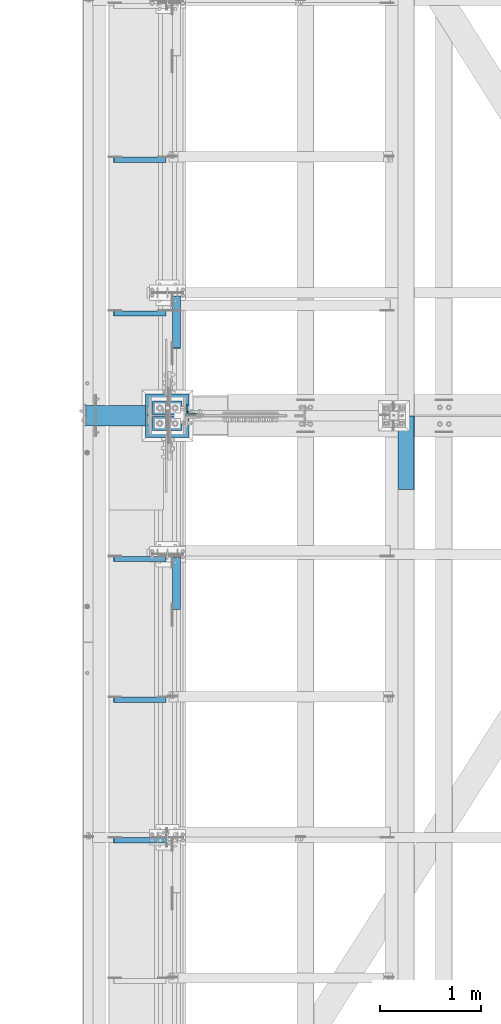
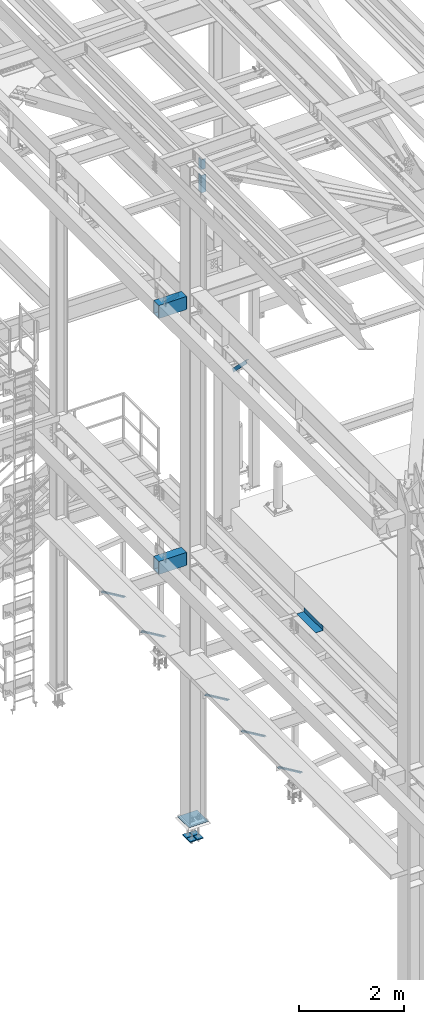
# One storey, part 2400 of 3843: 10 beams, 7 members, 11 elements without a shape of their own.
"""IFC2X3 building model written with IfcOpenShell, lengths in millimetres."""

from ifc_helpers import new_model, si_unit, frame, origin_with_axes, place, context, subcontext, project, spatial, faceted_brep, material, type_object, element, aggregate, save


model = new_model("IFC2X3")

# Units and contexts
model_context = context("Model", 3, precision=1e-05, world=origin_with_axes())
body_context = subcontext(model_context, "Body", "Model", "MODEL_VIEW")
ifc_project = project(units=[si_unit("LENGTHUNIT", "METRE", prefix="MILLI"), si_unit("AREAUNIT", "SQUARE_METRE"), si_unit("VOLUMEUNIT", "CUBIC_METRE"), si_unit("MASSUNIT", "GRAM", prefix="KILO"), si_unit("TIMEUNIT", "SECOND"), si_unit("PLANEANGLEUNIT", "RADIAN"), si_unit("SOLIDANGLEUNIT", "STERADIAN"), si_unit("THERMODYNAMICTEMPERATUREUNIT", "DEGREE_CELSIUS"), si_unit("LUMINOUSINTENSITYUNIT", "LUMEN")], contexts=[model_context])

# Site, building, storey
site_placement = place(None, origin_with_axes())
site = spatial("IfcSite", under=ifc_project, at=site_placement, CompositionType="ELEMENT")
building_placement = place(site_placement, origin_with_axes())
building = spatial("IfcBuilding", under=site, at=building_placement, Name="Undefined", CompositionType="ELEMENT")
storey_placement = place(building_placement, origin_with_axes())
storey = spatial("IfcBuildingStorey", under=building, at=storey_placement, Name="Undefined", CompositionType="ELEMENT", Elevation=0.0)

# Assembly, beam
assembly_1_placement = place(storey_placement, origin_with_axes())
assembly_1 = element("IfcElementAssembly", 1, at=assembly_1_placement, inside=storey, Name="BEAM", AssemblyPlace="NOTDEFINED", PredefinedType="RIGID_FRAME")
ifc_material_1 = material(Name="STEEL/A36")
beam_type_1 = type_object("IfcBeamType", PredefinedType="NOTDEFINED")
beam_1_placement = place(assembly_1_placement, frame((38858.825, 83616.8, 34039.175), z_axis=(0.0, -1.0, 0.0), x_axis=(1.0, 0.0, 0.0)))
beam_1 = element("IfcBeam", 2, at=beam_1_placement, type_object=beam_type_1, material=ifc_material_1, Name="BENT_PLATE", context=body_context, shape_type="Brep", body=[
    faceted_brep([(161.925005912773, 7.27595761418343e-12, 365.125000000029), (158.749999999993, 3.17500000000291, 361.950000000041), (0.0, 3.17500000000291, 361.950000000041), (0.0, 0.0, 365.125), (161.924999999988, 98.4249999999956, 365.125), (158.749999999993, 98.4249999999956, 361.950000000041), (165.099999999999, -3.17500000000291, -365.125), (0.0, -3.17500000000291, -365.125), (0.0, 3.17500000000291, -365.125), (158.749999999993, 3.17500000000291, -365.125), (158.749999999993, 98.4249999999956, -365.125), (165.099999999999, 98.4249999999956, -365.125), (165.099999999999, -3.17500000000291, 365.125), (165.099999999999, 98.4249999999956, 365.125), (0.0, -3.17500000000291, 365.125)], [[[0, 1, 2, 3]], [[4, 5, 1, 0]], [[6, 7, 8, 9, 10, 11]], [[12, 6, 11, 13]], [[14, 7, 6, 12]], [[8, 7, 14, 3, 2]], [[9, 8, 2, 1]], [[10, 9, 1, 5]], [[13, 11, 10, 5, 4]], [[14, 12, 13, 4, 0, 3]]]),
])
aggregate(assembly_1, [beam_1])

# Assembly, member
assembly_2_placement = place(storey_placement, origin_with_axes())
assembly_2 = element("IfcElementAssembly", 3, at=assembly_2_placement, inside=storey, Name="ANGLE", AssemblyPlace="NOTDEFINED", PredefinedType="RIGID_FRAME")
ifc_material_2 = material(Name="STEEL/A572-50")
member_type_1 = type_object("IfcMemberType", Name="L2X2X1/4", PredefinedType="NOTDEFINED")
member_1_placement = place(assembly_2_placement, frame((36032.7062481198, 86521.9250000001, 34001.5027629153), z_axis=(0.0, -1.0, 0.0), x_axis=(0.858158898344811, 0.0, -0.513384169206278)))
member_1 = element("IfcMember", 4, at=member_1_placement, type_object=member_type_1, material=ifc_material_2, Name="ANGLE", ObjectType="L2X2X1/4", context=body_context, shape_type="Brep", body=[
    faceted_brep([(0.0, 25.4000000000015, -25.4000000000015), (0.0, 25.4000000000015, 25.4000000000015), (598.473132324763, 25.3999999988228, 25.3999999999942), (598.473132324763, 25.3999999988228, -25.3999999999942), (0.0, 19.0500000000029, 25.4000000000015), (598.473132324745, 19.0499999988242, 25.3999999999942), (0.0, 19.0500000000029, -19.0499999999993), (598.473132324745, 19.0499999988242, -19.0500000000029), (0.0, -25.4000000000015, -19.0499999999993), (598.473132324661, -25.4000000011511, -19.0500000000029), (0.0, -25.4000000000015, -25.4000000000015), (598.473132324661, -25.4000000011511, -25.3999999999942)], [[[0, 1, 2, 3]], [[1, 4, 5, 2]], [[4, 6, 7, 5]], [[6, 8, 9, 7]], [[8, 10, 11, 9]], [[10, 0, 3, 11]], [[5, 7, 9, 11, 3, 2]], [[10, 8, 6, 4, 1, 0]]]),
])
aggregate(assembly_2, [member_1])

assembly_3_placement = place(storey_placement, origin_with_axes())
assembly_3 = element("IfcElementAssembly", 5, at=assembly_3_placement, inside=storey, Name="ANGLE", AssemblyPlace="NOTDEFINED", PredefinedType="RIGID_FRAME")
member_2_placement = place(assembly_3_placement, frame((36032.7062481198, 84997.9250000001, 34001.5027629153), z_axis=(0.0, -1.0, 0.0), x_axis=(0.858158898344811, 0.0, -0.513384169206278)))
member_2 = element("IfcMember", 6, at=member_2_placement, type_object=member_type_1, material=ifc_material_2, Name="ANGLE", ObjectType="L2X2X1/4", context=body_context, shape_type="Brep", body=[
    faceted_brep([(0.0, 25.4000000000015, -25.4000000000015), (0.0, 25.4000000000015, 25.4000000000015), (598.473132324763, 25.3999999988228, 25.3999999999942), (598.473132324763, 25.3999999988228, -25.3999999999942), (0.0, 19.0500000000029, 25.4000000000015), (598.473132324745, 19.0499999988242, 25.3999999999942), (0.0, 19.0500000000029, -19.0499999999993), (598.473132324745, 19.0499999988242, -19.0500000000029), (0.0, -25.4000000000015, -19.0499999999993), (598.473132324661, -25.4000000011511, -19.0500000000029), (0.0, -25.4000000000015, -25.4000000000015), (598.473132324661, -25.4000000011511, -25.3999999999942)], [[[0, 1, 2, 3]], [[1, 4, 5, 2]], [[4, 6, 7, 5]], [[6, 8, 9, 7]], [[8, 10, 11, 9]], [[10, 0, 3, 11]], [[5, 7, 9, 11, 3, 2]], [[10, 8, 6, 4, 1, 0]]]),
])
aggregate(assembly_3, [member_2])

assembly_4_placement = place(storey_placement, origin_with_axes())
assembly_4 = element("IfcElementAssembly", 7, at=assembly_4_placement, inside=storey, Name="ANGLE", AssemblyPlace="NOTDEFINED", PredefinedType="RIGID_FRAME")
member_3_placement = place(assembly_4_placement, frame((36032.7062481198, 82563.6921880001, 34001.5027629153), z_axis=(0.0, -1.0, 0.0), x_axis=(0.858158898344811, 0.0, -0.513384169206278)))
member_3 = element("IfcMember", 8, at=member_3_placement, type_object=member_type_1, material=ifc_material_2, Name="ANGLE", ObjectType="L2X2X1/4", context=body_context, shape_type="Brep", body=[
    faceted_brep([(0.0, 25.4000000000015, -25.4000000000015), (0.0, 25.4000000000015, 25.4000000000015), (598.473132324763, 25.3999999988228, 25.3999999999942), (598.473132324763, 25.3999999988228, -25.3999999999942), (0.0, 19.0500000000029, 25.4000000000015), (598.473132324745, 19.0499999988242, 25.3999999999942), (0.0, 19.0500000000029, -19.0499999999993), (598.473132324745, 19.0499999988242, -19.0500000000029), (0.0, -25.4000000000015, -19.0499999999993), (598.473132324661, -25.4000000011511, -19.0500000000029), (0.0, -25.4000000000015, -25.4000000000015), (598.473132324661, -25.4000000011511, -25.3999999999942)], [[[0, 1, 2, 3]], [[1, 4, 5, 2]], [[4, 6, 7, 5]], [[6, 8, 9, 7]], [[8, 10, 11, 9]], [[10, 0, 3, 11]], [[5, 7, 9, 11, 3, 2]], [[10, 8, 6, 4, 1, 0]]]),
])
aggregate(assembly_4, [member_3])

assembly_5_placement = place(storey_placement, origin_with_axes())
assembly_5 = element("IfcElementAssembly", 9, at=assembly_5_placement, inside=storey, Name="ANGLE", AssemblyPlace="NOTDEFINED", PredefinedType="RIGID_FRAME")
member_4_placement = place(assembly_5_placement, frame((36032.7062481198, 81170.8593760001, 34001.5027629153), z_axis=(0.0, -1.0, 0.0), x_axis=(0.858158898344811, 0.0, -0.513384169206278)))
member_4 = element("IfcMember", 10, at=member_4_placement, type_object=member_type_1, material=ifc_material_2, Name="ANGLE", ObjectType="L2X2X1/4", context=body_context, shape_type="Brep", body=[
    faceted_brep([(0.0, 25.4000000000015, -25.4000000000015), (0.0, 25.4000000000015, 25.4000000000015), (598.473132324763, 25.3999999988228, 25.3999999999942), (598.473132324763, 25.3999999988228, -25.3999999999942), (0.0, 19.0500000000029, 25.4000000000015), (598.473132324745, 19.0499999988242, 25.3999999999942), (0.0, 19.0500000000029, -19.0499999999993), (598.473132324745, 19.0499999988242, -19.0500000000029), (0.0, -25.4000000000015, -19.0499999999993), (598.473132324661, -25.4000000011511, -19.0500000000029), (0.0, -25.4000000000015, -25.4000000000015), (598.473132324661, -25.4000000011511, -25.3999999999942)], [[[0, 1, 2, 3]], [[1, 4, 5, 2]], [[4, 6, 7, 5]], [[6, 8, 9, 7]], [[8, 10, 11, 9]], [[10, 0, 3, 11]], [[5, 7, 9, 11, 3, 2]], [[10, 8, 6, 4, 1, 0]]]),
])
aggregate(assembly_5, [member_4])

assembly_6_placement = place(storey_placement, origin_with_axes())
assembly_6 = element("IfcElementAssembly", 11, at=assembly_6_placement, inside=storey, Name="ANGLE", AssemblyPlace="NOTDEFINED", PredefinedType="RIGID_FRAME")
member_5_placement = place(assembly_6_placement, frame((36032.7062481198, 79778.1257820001, 34001.5027629153), z_axis=(0.0, -1.0, 0.0), x_axis=(0.858158898344811, 0.0, -0.513384169206278)))
member_5 = element("IfcMember", 12, at=member_5_placement, type_object=member_type_1, material=ifc_material_2, Name="ANGLE", ObjectType="L2X2X1/4", context=body_context, shape_type="Brep", body=[
    faceted_brep([(0.0, 25.4000000000015, -25.4000000000015), (0.0, 25.4000000000015, 25.4000000000015), (598.473132324763, 25.3999999988228, 25.3999999999942), (598.473132324763, 25.3999999988228, -25.3999999999942), (0.0, 19.0500000000029, 25.4000000000015), (598.473132324745, 19.0499999988242, 25.3999999999942), (0.0, 19.0500000000029, -19.0499999999993), (598.473132324745, 19.0499999988242, -19.0500000000029), (0.0, -25.4000000000015, -19.0499999999993), (598.473132324661, -25.4000000011511, -19.0500000000029), (0.0, -25.4000000000015, -25.4000000000015), (598.473132324661, -25.4000000011511, -25.3999999999942)], [[[0, 1, 2, 3]], [[1, 4, 5, 2]], [[4, 6, 7, 5]], [[6, 8, 9, 7]], [[8, 10, 11, 9]], [[10, 0, 3, 11]], [[5, 7, 9, 11, 3, 2]], [[10, 8, 6, 4, 1, 0]]]),
])
aggregate(assembly_6, [member_5])

# Assembly, beams
assembly_7_placement = place(storey_placement, origin_with_axes())
assembly_7 = element("IfcElementAssembly", 13, at=assembly_7_placement, inside=storey, Name="COLUMN", AssemblyPlace="NOTDEFINED", PredefinedType="RIGID_FRAME")
ifc_material_3 = material()
beam_type_2 = type_object("IfcBeamType", Name="HSS12X8X3/8", PredefinedType="NOTDEFINED")
beam_2_placement = place(assembly_7_placement, frame((35760.025, 83985.1, 42214.8), z_axis=(0.0, 0.0, 1.0), x_axis=(1.0, 0.0, 0.0)))
beam_2 = element("IfcBeam", 14, at=beam_2_placement, type_object=beam_type_2, material=ifc_material_3, Name="GIRT", ObjectType="HSS12X8X3/8", context=body_context, shape_type="Brep", body=[
    faceted_brep([(625.474999999999, 92.0749999999971, 142.875), (625.474999999999, 92.0749999999971, -142.875), (615.949999999997, 101.600000000006, -152.400000000001), (615.949999999997, 101.600000000006, 152.400000000001), (625.474999999999, -92.0749999999971, -142.875), (615.949999999997, -101.600000000006, -152.400000000001), (625.474999999999, -92.0749999999971, 142.875), (615.949999999997, -101.600000000006, 152.400000000001), (6.35000000002037, 92.0749999999971, 142.875), (6.35000000002037, 92.0749999999971, -142.875), (6.35000000002037, -92.0749999999971, 142.875), (6.35000000002037, -92.0749999999971, -142.875), (6.35000000002037, -101.600000000006, -152.400000000001), (6.35000000002037, -101.600000000006, 152.400000000001), (6.35000000002037, 101.600000000006, 152.400000000001), (6.35000000002037, 101.600000000006, -152.400000000001)], [[[0, 1, 2, 3]], [[4, 5, 2, 1]], [[6, 7, 5, 4]], [[8, 9, 1, 0]], [[10, 8, 0, 6]], [[11, 10, 6, 4]], [[9, 11, 4, 1]], [[12, 13, 14, 15], [8, 10, 11, 9]], [[15, 14, 3, 2]], [[12, 15, 2, 5]], [[13, 12, 5, 7]], [[14, 13, 7, 3]], [[0, 3, 7, 6]]]),
])
beam_3_placement = place(assembly_7_placement, frame((35760.025, 83985.1, 36252.15), z_axis=(0.0, 0.0, 1.0), x_axis=(1.0, 0.0, 0.0)))
beam_3 = element("IfcBeam", 15, at=beam_3_placement, type_object=beam_type_2, material=ifc_material_3, Name="BEAM", ObjectType="HSS12X8X3/8", context=body_context, shape_type="Brep", body=[
    faceted_brep([(625.474999999999, 92.0749999999971, 142.875), (625.474999999999, 92.0749999999971, -142.875), (615.949999999997, 101.600000000006, -152.400000000001), (615.949999999997, 101.600000000006, 152.400000000001), (625.474999999999, -92.0749999999971, -142.875), (615.949999999997, -101.600000000006, -152.400000000001), (625.474999999999, -92.0749999999971, 142.875), (615.949999999997, -101.600000000006, 152.400000000001), (6.35000000002037, 92.0749999999971, 142.875), (6.35000000002037, 92.0749999999971, -142.875), (6.35000000002037, -92.0749999999971, 142.875), (6.35000000002037, -92.0749999999971, -142.875), (6.35000000002037, -101.600000000006, -152.400000000001), (6.35000000002037, -101.600000000006, 152.400000000001), (6.35000000002037, 101.600000000006, 152.400000000001), (6.35000000002037, 101.600000000006, -152.400000000001)], [[[0, 1, 2, 3]], [[4, 5, 2, 1]], [[6, 7, 5, 4]], [[8, 9, 1, 0]], [[10, 8, 0, 6]], [[11, 10, 6, 4]], [[9, 11, 4, 1]], [[12, 13, 14, 15], [8, 10, 11, 9]], [[15, 14, 3, 2]], [[12, 15, 2, 5]], [[13, 12, 5, 7]], [[14, 13, 7, 3]], [[0, 3, 7, 6]]]),
])
aggregate(assembly_7, [beam_2, beam_3])

assembly_8_placement = place(storey_placement, origin_with_axes())
assembly_8 = element("IfcElementAssembly", 16, at=assembly_8_placement, inside=storey, Name="BEAM", AssemblyPlace="NOTDEFINED", PredefinedType="RIGID_FRAME")
beam_type_3 = type_object("IfcBeamType", Name="L4X4X5/8", PredefinedType="NOTDEFINED")
beam_4_placement = place(assembly_8_placement, frame((36810.95, 84045.4249996185, 44978.4221334664), z_axis=(0.0, 1.0, 0.0), x_axis=(0.0, 0.0, -1.0)))
beam_4 = element("IfcBeam", 17, at=beam_4_placement, type_object=beam_type_3, material=ifc_material_2, Name="ANGLE", ObjectType="L4X4X5/8", context=body_context, shape_type="Brep", body=[
    faceted_brep([(0.0, 50.8000000000029, -50.8000000000029), (0.0, 50.8000000000029, 50.8000000000029), (406.399999999841, 50.799999998344, 50.8000000000029), (406.399999999841, 50.799999998344, -50.8000000000029), (0.0, 34.9250000000029, 50.8000000000029), (406.399999999892, 34.924999998344, 50.8000000000029), (0.0, 34.9250000000029, -34.9250000000029), (406.399999999892, 34.924999998344, -34.9250000000029), (0.0, -50.8000000000029, -34.9250000000029), (406.400000000162, -50.8000000016473, -34.9250000000029), (0.0, -50.8000000000029, -50.8000000000029), (406.400000000162, -50.8000000016473, -50.8000000000029)], [[[0, 1, 2, 3]], [[1, 4, 5, 2]], [[4, 6, 7, 5]], [[6, 8, 9, 7]], [[8, 10, 11, 9]], [[10, 0, 3, 11]], [[5, 7, 9, 11, 3, 2]], [[10, 8, 6, 4, 1, 0]]]),
])
beam_5_placement = place(assembly_8_placement, frame((36810.9499999688, 84047.0120004654, 45342.1750030886), z_axis=(0.0, 1.0, 0.0), x_axis=(0.0, 0.0, -1.0)))
beam_5 = element("IfcBeam", 18, at=beam_5_placement, type_object=beam_type_3, material=ifc_material_2, Name="ANGLE", ObjectType="L4X4X5/8", context=body_context, shape_type="Brep", body=[
    faceted_brep([(0.0, 50.8000000000029, -50.8000000000029), (0.0, 50.8000000000029, 50.8000000000029), (228.600164820818, 50.8000000000029, 50.8000000000029), (228.600164820818, 50.8000000000029, -50.8000000000029), (0.0, 34.9250000000029, 50.8000000000029), (228.600164820818, 34.9250000000029, 50.8000000000029), (0.0, 34.9250000000029, -34.9250000000029), (228.600164820818, 34.9250000000029, -34.9250000000029), (0.0, -50.8000000000029, -34.9250000000029), (228.600164820818, -50.8000000000029, -34.9250000000029), (0.0, -50.8000000000029, -50.8000000000029), (228.600164820818, -50.8000000000029, -50.8000000000029)], [[[0, 1, 2, 3]], [[1, 4, 5, 2]], [[4, 6, 7, 5]], [[6, 8, 9, 7]], [[8, 10, 11, 9]], [[10, 0, 3, 11]], [[5, 7, 9, 11, 3, 2]], [[10, 8, 6, 4, 1, 0]]]),
])
aggregate(assembly_8, [beam_4, beam_5])

# Assembly, member
assembly_9_placement = place(storey_placement, origin_with_axes())
assembly_9 = element("IfcElementAssembly", 19, at=assembly_9_placement, inside=storey, Name="ANGLE", AssemblyPlace="NOTDEFINED", PredefinedType="RIGID_FRAME")
member_type_2 = type_object("IfcMemberType", Name="L3X3X1/4", PredefinedType="NOTDEFINED")
member_6_placement = place(assembly_9_placement, frame((36664.9, 82613.5, 41300.4), z_axis=(0.0, -0.707106781186548, -0.707106781186548), x_axis=(0.0, -0.707106781186682, 0.707106781186413)))
member_6 = element("IfcMember", 20, at=member_6_placement, type_object=member_type_2, material=ifc_material_2, Name="ANGLE", ObjectType="L3X3X1/4", context=body_context, shape_type="Brep", body=[
    faceted_brep([(83.0012806675732, 38.0999999999985, -38.0999999999058), (83.0012806675732, -38.0999999999985, -38.0999999999058), (83.0012806675804, -38.0999999999985, -31.7499999999254), (83.0012806675804, 31.75, -31.7499999999254), (83.0012806675804, 31.75, 38.0999999999058), (83.0012806675804, 38.0999999999985, 38.0999999999058), (810.534203444928, 31.75, 38.0999999999112), (810.534203444928, 38.0999999999985, 38.0999999999112), (810.534203444538, 38.0999999999985, -38.099999999904), (810.534203444538, -38.0999999999985, -38.099999999904), (810.534203444575, -38.0999999999985, -31.7499999999272), (810.534203444575, 31.75, -31.7499999999272)], [[[0, 1, 2, 3, 4, 5]], [[5, 4, 6, 7]], [[0, 5, 7, 8]], [[1, 0, 8, 9]], [[2, 1, 9, 10]], [[3, 2, 10, 11]], [[4, 3, 11, 6]], [[10, 9, 8, 7, 6, 11]]]),
])
aggregate(assembly_9, [member_6])

assembly_10_placement = place(storey_placement, origin_with_axes())
assembly_10 = element("IfcElementAssembly", 21, at=assembly_10_placement, inside=storey, Name="ANGLE", AssemblyPlace="NOTDEFINED", PredefinedType="RIGID_FRAME")
member_7_placement = place(assembly_10_placement, frame((36664.9, 85204.3, 41300.4), z_axis=(0.0, -0.707106781186548, -0.707106781186548), x_axis=(0.0, -0.707106781186682, 0.707106781186413)))
member_7 = element("IfcMember", 22, at=member_7_placement, type_object=member_type_2, material=ifc_material_2, Name="ANGLE", ObjectType="L3X3X1/4", context=body_context, shape_type="Brep", body=[
    faceted_brep([(83.0012806675732, 38.0999999999985, -38.0999999999058), (83.0012806675732, -38.0999999999985, -38.0999999999058), (83.0012806675804, -38.0999999999985, -31.7499999999254), (83.0012806675804, 31.75, -31.7499999999254), (83.0012806675804, 31.75, 38.0999999999058), (83.0012806675804, 38.0999999999985, 38.0999999999058), (810.534203444928, 31.75, 38.0999999999112), (810.534203444928, 38.0999999999985, 38.0999999999112), (810.534203444538, 38.0999999999985, -38.099999999904), (810.534203444538, -38.0999999999985, -38.099999999904), (810.534203444575, -38.0999999999985, -31.7499999999272), (810.534203444575, 31.75, -31.7499999999272)], [[[0, 1, 2, 3, 4, 5]], [[5, 4, 6, 7]], [[0, 5, 7, 8]], [[1, 0, 8, 9]], [[2, 1, 9, 10]], [[3, 2, 10, 11]], [[4, 3, 11, 6]], [[10, 9, 8, 7, 6, 11]]]),
])
aggregate(assembly_10, [member_7])

# Assembly, beams
assembly_11_placement = place(storey_placement, origin_with_axes())
assembly_11 = element("IfcElementAssembly", 23, at=assembly_11_placement, inside=storey, Name="TEMPLATE", AssemblyPlace="NOTDEFINED", PredefinedType="RIGID_FRAME")
beam_type_4 = type_object("IfcBeamType", PredefinedType="NOTDEFINED")
beam_6_placement = place(assembly_11_placement, frame((36722.05, 83908.9, 29656.0875), z_axis=(0.0, 1.0, 0.0), x_axis=(-1.0, 0.0, 0.0)))
beam_6 = element("IfcBeam", 24, at=beam_6_placement, type_object=beam_type_4, material=ifc_material_2, context=body_context, shape_type="Brep", body=[
    faceted_brep([(0.0, 11.1124999999993, -69.8499999999985), (0.0, 11.1124999999993, 69.8499999999985), (139.699999999997, 11.1124999999993, 69.8499999999985), (139.699999999997, 11.1124999999993, -69.8499999999985), (0.0, -11.1124999999993, 69.8499999999985), (139.699999999997, -11.1124999999993, 69.8499999999985), (0.0, -11.1124999999993, -69.8499999999985), (139.699999999997, -11.1124999999993, -69.8499999999985)], [[[0, 1, 2, 3]], [[1, 4, 5, 2]], [[4, 6, 7, 5]], [[6, 0, 3, 7]], [[5, 7, 3, 2]], [[6, 4, 1, 0]]]),
])
beam_7_placement = place(assembly_11_placement, frame((36722.05, 84061.3, 29656.0875), z_axis=(0.0, 1.0, 0.0), x_axis=(-1.0, 0.0, 0.0)))
beam_7 = element("IfcBeam", 25, at=beam_7_placement, type_object=beam_type_4, material=ifc_material_2, context=body_context, shape_type="Brep", body=[
    faceted_brep([(0.0, 11.1124999999993, -69.8499999999985), (0.0, 11.1124999999993, 69.8499999999985), (139.699999999997, 11.1124999999993, 69.8499999999985), (139.699999999997, 11.1124999999993, -69.8499999999985), (0.0, -11.1124999999993, 69.8499999999985), (139.699999999997, -11.1124999999993, 69.8499999999985), (0.0, -11.1124999999993, -69.8499999999985), (139.699999999997, -11.1124999999993, -69.8499999999985)], [[[0, 1, 2, 3]], [[1, 4, 5, 2]], [[4, 6, 7, 5]], [[6, 0, 3, 7]], [[5, 7, 3, 2]], [[6, 4, 1, 0]]]),
])
beam_8_placement = place(assembly_11_placement, frame((36569.65, 83908.9, 29656.0875), z_axis=(0.0, 1.0, 0.0), x_axis=(-1.0, 0.0, 0.0)))
beam_8 = element("IfcBeam", 26, at=beam_8_placement, type_object=beam_type_4, material=ifc_material_2, context=body_context, shape_type="Brep", body=[
    faceted_brep([(0.0, 11.1124999999993, -69.8499999999985), (0.0, 11.1124999999993, 69.8499999999985), (139.699999999997, 11.1124999999993, 69.8499999999985), (139.699999999997, 11.1124999999993, -69.8499999999985), (0.0, -11.1124999999993, 69.8499999999985), (139.699999999997, -11.1124999999993, 69.8499999999985), (0.0, -11.1124999999993, -69.8499999999985), (139.699999999997, -11.1124999999993, -69.8499999999985)], [[[0, 1, 2, 3]], [[1, 4, 5, 2]], [[4, 6, 7, 5]], [[6, 0, 3, 7]], [[5, 7, 3, 2]], [[6, 4, 1, 0]]]),
])
beam_9_placement = place(assembly_11_placement, frame((36569.65, 84061.3, 29656.0875), z_axis=(0.0, 1.0, 0.0), x_axis=(-1.0, 0.0, 0.0)))
beam_9 = element("IfcBeam", 27, at=beam_9_placement, type_object=beam_type_4, material=ifc_material_2, context=body_context, shape_type="Brep", body=[
    faceted_brep([(0.0, 11.1124999999993, -69.8499999999985), (0.0, 11.1124999999993, 69.8499999999985), (139.699999999997, 11.1124999999993, 69.8499999999985), (139.699999999997, 11.1124999999993, -69.8499999999985), (0.0, -11.1124999999993, 69.8499999999985), (139.699999999997, -11.1124999999993, 69.8499999999985), (0.0, -11.1124999999993, -69.8499999999985), (139.699999999997, -11.1124999999993, -69.8499999999985)], [[[0, 1, 2, 3]], [[1, 4, 5, 2]], [[4, 6, 7, 5]], [[6, 0, 3, 7]], [[5, 7, 3, 2]], [[6, 4, 1, 0]]]),
])
beam_type_5 = type_object("IfcBeamType", PredefinedType="NOTDEFINED")
beam_10_placement = place(assembly_11_placement, frame((36791.9, 83985.1, 30064.075), z_axis=(0.0, -1.0, 0.0), x_axis=(-1.0, 0.0, 0.0)))
beam_10 = element("IfcBeam", 28, at=beam_10_placement, type_object=beam_type_5, material=ifc_material_2, Name="TEMPLATE", context=body_context, shape_type="Brep", body=[
    faceted_brep([(0.0, 3.17499999999927, -215.900000000001), (0.0, 3.17499999999927, 215.900000000001), (431.799999999988, 3.17499999999927, 215.900000000001), (431.799999999988, 3.17499999999927, -215.900000000001), (0.0, -3.17499999999927, 215.900000000001), (431.799999999988, -3.17499999999927, 215.900000000001), (0.0, -3.17499999999927, -215.900000000001), (431.799999999988, -3.17499999999927, -215.900000000001)], [[[0, 1, 2, 3]], [[1, 4, 5, 2]], [[4, 6, 7, 5]], [[6, 0, 3, 7]], [[5, 7, 3, 2]], [[6, 4, 1, 0]]]),
])
aggregate(assembly_11, [beam_6, beam_7, beam_8, beam_9, beam_10])

save(model, "model.ifc")
